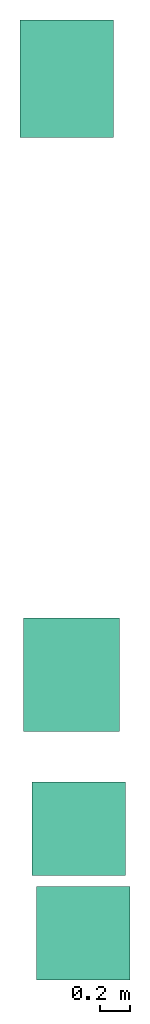
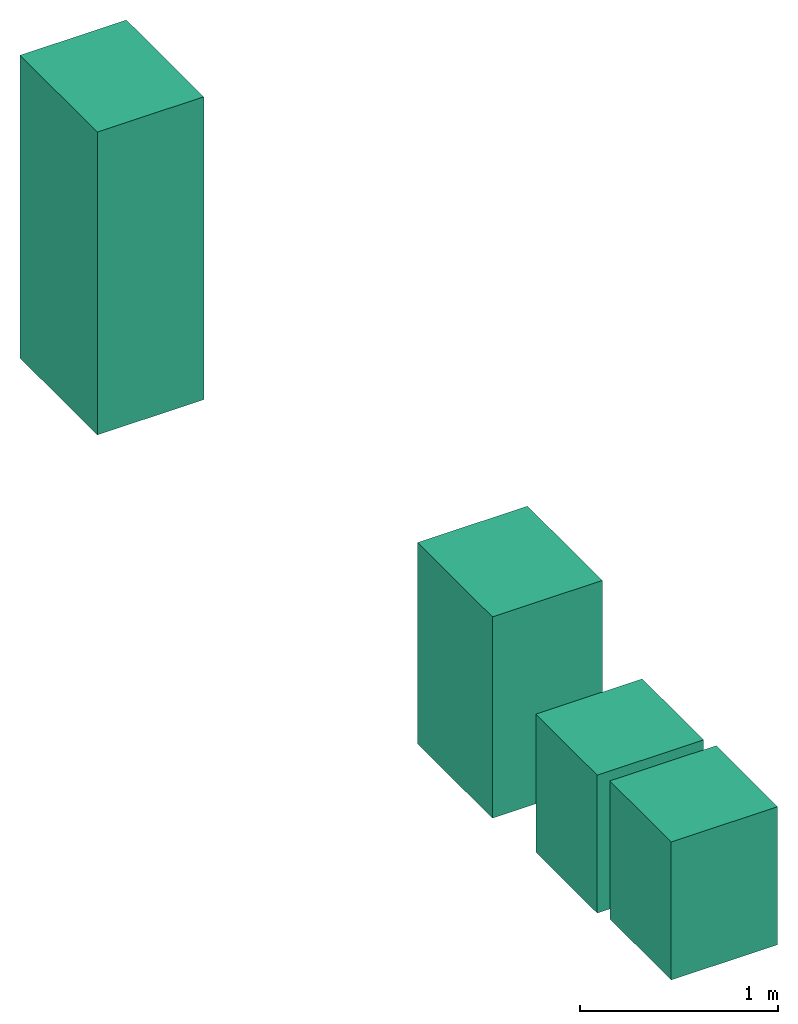
# Not in any storey: 4 electric appliances.
"""IFC4 building model written with IfcOpenShell, lengths in millimetres."""

import ifcopenshell
import ifcopenshell.guid

model = None  # the IFC model being written
_history = None  # IfcOwnerHistory: only IFC2X3 demands one
_inside = {}  # id of a spatial element -> (the spatial element, [elements in it])
_under = {}  # id of a project, library or spatial element -> (it, [spatial elements below it])
_declared = {}  # id of a project -> (the project, [libraries it declares])
_typed = {}  # id of a type object -> (the type object, [elements of that type])
_made_of = {}  # id of a material, layer set ... -> (it, [elements and type objects made of it])


def new_model(schema):
    """Start an empty IFC model of exactly this schema.

    Asked for "IFC4X3", IfcOpenShell would pick the latest addendum, in which some entities
    have other attributes; the version numbers below select the first issue.
    IFC2X3 requires an IfcOwnerHistory on every rooted entity: one is made here for all.
    """
    global model, _history
    if schema == "IFC4X3":
        model = ifcopenshell.file(schema_version=(4, 3, 0, 0))
    else:
        model = ifcopenshell.file(schema=schema)
    _inside.clear()
    _under.clear()
    _declared.clear()
    _typed.clear()
    _made_of.clear()
    _history = None
    if model.schema == "IFC2X3":
        org = make("IfcOrganization", Name="unknown")
        user = make(
            "IfcPersonAndOrganization",
            ThePerson=make("IfcPerson", FamilyName="unknown"),
            TheOrganization=org,
        )
        app = make(
            "IfcApplication",
            ApplicationDeveloper=org,
            Version="unknown",
            ApplicationFullName="unknown",
            ApplicationIdentifier="unknown",
        )
        _history = make(
            "IfcOwnerHistory",
            OwningUser=user,
            OwningApplication=app,
            ChangeAction="ADDED",
            CreationDate=0,
        )
    return model


def make(cls, **values):
    """One entity of the class cls with the attributes given. An attribute that is None is left unset."""
    return model.create_entity(
        cls, **{name: value for name, value in values.items() if value is not None}
    )


def entity(cls, *values):
    """Any entity or typed value of the class cls, its attributes in the order of the schema. None: left unset."""
    e = model.create_entity(cls)
    for i, value in enumerate(values):
        if value is not None:
            e[i] = value
    return e


def rooted(cls, **values):
    """An entity with a GlobalId (a new one), such as an element, a storey or a relation."""
    return make(cls, GlobalId=ifcopenshell.guid.new(), OwnerHistory=_history, **values)


def si_unit(unit_type, name, prefix=None):
    """IfcSIUnit, for example si_unit("LENGTHUNIT", "METRE", prefix="MILLI")."""
    return make("IfcSIUnit", UnitType=unit_type, Prefix=prefix, Name=name)


def converted_unit(unit_type, name, factor, base, dimensions=None, offset=None):
    """IfcConversionBasedUnit, such as the inch: factor (a typed value) times the base unit."""
    return make(
        "IfcConversionBasedUnit"
        if offset is None
        else "IfcConversionBasedUnitWithOffset",
        ConversionOffset=offset,
        Dimensions=None
        if dimensions is None
        else entity("IfcDimensionalExponents", *dimensions),
        UnitType=unit_type,
        Name=name,
        ConversionFactor=make(
            "IfcMeasureWithUnit", ValueComponent=factor, UnitComponent=base
        ),
    )


def assignment(units):
    """IfcUnitAssignment: the units of a project."""
    return None if units is None else make("IfcUnitAssignment", Units=units)


def point(xyz):
    """IfcCartesianPoint."""
    return None if xyz is None else make("IfcCartesianPoint", Coordinates=xyz)


def direction(xyz):
    """IfcDirection."""
    return None if xyz is None else make("IfcDirection", DirectionRatios=xyz)


def frame(location, z_axis=None, x_axis=None):
    """IfcAxis2Placement3D, a coordinate frame: its origin and axes. An axis left out is left unset."""
    return make(
        "IfcAxis2Placement3D",
        Location=point(location),
        Axis=direction(z_axis),
        RefDirection=direction(x_axis),
    )


def frame_2d(location, x_axis=None):
    """IfcAxis2Placement2D, a coordinate frame in the plane: its origin and x axis."""
    return make(
        "IfcAxis2Placement2D", Location=point(location), RefDirection=direction(x_axis)
    )


def origin_with_axes():
    """The frame at (0, 0, 0) with the z axis (0, 0, 1) and the x axis (1, 0, 0) written out."""
    return frame((0.0, 0.0, 0.0), z_axis=(0.0, 0.0, 1.0), x_axis=(1.0, 0.0, 0.0))


def origin_2d_with_axis():
    """The frame at (0, 0) in the plane with the x axis (1, 0) written out."""
    return frame_2d((0.0, 0.0), x_axis=(1.0, 0.0))


def place(relative_to, where):
    """IfcLocalPlacement: puts the frame where relative to a parent placement (None: the world)."""
    return make(
        "IfcLocalPlacement", PlacementRelTo=relative_to, RelativePlacement=where
    )


def context(
    kind, dimensions, precision=None, world=None, true_north=None, identifier=None
):
    """IfcGeometricRepresentationContext, for example the 3D "Model" context."""
    return make(
        "IfcGeometricRepresentationContext",
        ContextIdentifier=identifier,
        ContextType=kind,
        CoordinateSpaceDimension=dimensions,
        Precision=precision,
        WorldCoordinateSystem=world,
        TrueNorth=true_north,
    )


def subcontext(parent, identifier, kind, view, scale=None):
    """IfcGeometricRepresentationSubContext, for example "Body" below "Model"."""
    return make(
        "IfcGeometricRepresentationSubContext",
        ContextIdentifier=identifier,
        ContextType=kind,
        ParentContext=parent,
        TargetScale=scale,
        TargetView=view,
    )


def project(units=None, contexts=None):
    """IfcProject with its units and contexts."""
    return rooted(
        "IfcProject",
        Name="project",
        RepresentationContexts=contexts,
        UnitsInContext=assignment(units),
    )


def spatial(cls, under=None, at=None, **own):
    """A site, building, storey or space (cls), placed at a placement, below another one or the project."""
    s = rooted(cls, ObjectPlacement=at, **own)
    if under is not None:
        _under.setdefault(under.id(), (under, []))[1].append(s)
    return s


def point_list(points):
    """IfcCartesianPointList2D or 3D."""
    cls = (
        "IfcCartesianPointList2D" if len(points[0]) == 2 else "IfcCartesianPointList3D"
    )
    return make(cls, CoordList=points)


def polygons(points, faces, closed=None, point_numbers=None):
    """IfcPolygonalFaceSet: a face is its outer loop, then its inner loops; points numbered from 1."""
    made = []
    for loops in faces:
        if len(loops) == 1:
            made.append(make("IfcIndexedPolygonalFace", CoordIndex=loops[0]))
        else:
            made.append(
                make(
                    "IfcIndexedPolygonalFaceWithVoids",
                    CoordIndex=loops[0],
                    InnerCoordIndices=loops[1:],
                )
            )
    return make(
        "IfcPolygonalFaceSet",
        Coordinates=point_list(points),
        Closed=closed,
        Faces=made,
        PnIndex=point_numbers,
    )


def shape(context_of_items, identifier, shape_type, items):
    """IfcShapeRepresentation: the items that make up one representation, for example the "Body"."""
    return make(
        "IfcShapeRepresentation",
        ContextOfItems=context_of_items,
        RepresentationIdentifier=identifier,
        RepresentationType=shape_type,
        Items=items,
    )


def source(mapping_origin, context_of_items, identifier, shape_type, items):
    """IfcRepresentationMap: a shape defined once, which mapped items show again and again."""
    return make(
        "IfcRepresentationMap",
        MappingOrigin=mapping_origin,
        MappedRepresentation=shape(context_of_items, identifier, shape_type, items),
    )


def transform(
    local_origin,
    x_axis=None,
    y_axis=None,
    z_axis=None,
    scale=None,
    scale2=None,
    scale3=None,
    uniform=True,
):
    """IfcCartesianTransformationOperator3D, or its non-uniform kind. x_axis, y_axis, z_axis: its Axis1, 2, 3."""
    if uniform:
        return make(
            "IfcCartesianTransformationOperator3D",
            Axis1=direction(x_axis),
            Axis2=direction(y_axis),
            LocalOrigin=point(local_origin),
            Scale=scale,
            Axis3=direction(z_axis),
        )
    return make(
        "IfcCartesianTransformationOperator3DnonUniform",
        Axis1=direction(x_axis),
        Axis2=direction(y_axis),
        LocalOrigin=point(local_origin),
        Scale=scale,
        Axis3=direction(z_axis),
        Scale2=scale2,
        Scale3=scale3,
    )


def mapped(mapping_source, mapping_target):
    """IfcMappedItem: shows the shape of a source again, moved by a transform."""
    return make(
        "IfcMappedItem", MappingSource=mapping_source, MappingTarget=mapping_target
    )


def made_of(thing, what):
    """Note that an element or type object is made of a material, layer set ...; save() writes the relation."""
    if what is not None:
        _made_of.setdefault(what.id(), (what, []))[1].append(thing)
    return thing


def type_object(cls, material=None, **own):
    """A type object (cls), such as IfcWallType, which elements share."""
    return made_of(rooted(cls, **own), material)


def type_shapes(of_type, sources):
    """Give a type object the sources (RepresentationMaps) that its elements show as mapped items."""
    of_type.RepresentationMaps = sources


def element(
    cls,
    number,
    at=None,
    inside=None,
    cuts=None,
    type_object=None,
    material=None,
    context=None,
    identifier="Body",
    shape_type=None,
    held_by="IfcProductDefinitionShape",
    body=None,
    shapes=None,
    **own,
):
    """One element of the class cls, such as IfcWall. Its Tag is "e" and its number.

    at: its placement. inside: the storey or other place that contains it. cuts: it is an
    opening in that element (IfcRelVoidsElement). A single representation is given by context,
    identifier, shape_type and body (its items); several are given by shapes. held_by: the class
    of the entity that holds the representations. save() writes the other relations.
    """
    e = rooted(cls, Tag="e%d" % number, ObjectPlacement=at, **own)
    if body is not None:
        shapes = [shape(context, identifier, shape_type, body)]
    if shapes is not None:
        e.Representation = make(held_by, Representations=shapes)
    if inside is not None:
        _inside.setdefault(inside.id(), (inside, []))[1].append(e)
    if cuts is not None:
        rooted(
            "IfcRelVoidsElement", RelatingBuildingElement=cuts, RelatedOpeningElement=e
        )
    if type_object is not None:
        _typed.setdefault(type_object.id(), (type_object, []))[1].append(e)
    return made_of(e, material)


def aggregate(whole, parts):
    """IfcRelAggregates: a whole, such as a stair, and the parts it consists of."""
    return rooted("IfcRelAggregates", RelatingObject=whole, RelatedObjects=parts)


def save(model, path):
    """Write the relations noted so far, then the file.

    IfcRelAggregates (storeys below a building ...), IfcRelContainedInSpatialStructure (elements
    in a storey), IfcRelDefinesByType, IfcRelAssociatesMaterial and IfcRelDeclares: one each for
    every whole, place, type object, material and project.
    """
    for whole, parts in _under.values():
        aggregate(whole, parts)
    for where, things in _inside.values():
        rooted(
            "IfcRelContainedInSpatialStructure",
            RelatedElements=things,
            RelatingStructure=where,
        )
    for kind, things in _typed.values():
        rooted("IfcRelDefinesByType", RelatedObjects=things, RelatingType=kind)
    for what, things in _made_of.values():
        rooted("IfcRelAssociatesMaterial", RelatedObjects=things, RelatingMaterial=what)
    for by, libraries in _declared.values():
        rooted("IfcRelDeclares", RelatingContext=by, RelatedDefinitions=libraries)
    model.write(path)


model = new_model("IFC4")

# Units and contexts
model_context = context("Model", 3, precision=1e-05, world=origin_with_axes())
plan_context = context("Plan", 2, precision=1e-05, world=origin_2d_with_axis())
body_context = subcontext(model_context, "Body", "Model", "MODEL_VIEW")
ifc_project = project(units=[si_unit("VOLUMEUNIT", "CUBIC_METRE"), si_unit("LENGTHUNIT", "METRE", prefix="MILLI"), converted_unit("PLANEANGLEUNIT", "degree", entity("IfcReal", 0.0174532925199433), si_unit("PLANEANGLEUNIT", "RADIAN"), dimensions=[0, 0, 0, 0, 0, 0, 0]), si_unit("AREAUNIT", "SQUARE_METRE")], contexts=[model_context, plan_context])

# Site, buildings
site_placement = place(None, origin_with_axes())
site = spatial("IfcSite", under=ifc_project, at=site_placement)
building_1_placement = place(site_placement, origin_with_axes())
building_1 = spatial("IfcBuilding", under=site, at=building_1_placement, Name="Building")
building_2_placement = place(building_1_placement, origin_with_axes())
building_2 = spatial("IfcBuilding", under=building_1, at=building_2_placement, Name="Electrical")

# Electric appliances
electric_appliance_type_1 = type_object("IfcElectricApplianceType", Name="13 plate DW", PredefinedType="DISHWASHER")
shared_shape_1 = source(origin_with_axes(), body_context, "Body", "Tessellation", [
    polygons([(-25.4548778533936, -5.45489740371704, 2.98023205687059e-05), (-25.4548778533936, 614.544921875, 2.98023205687059e-05), (-25.4548778533936, -5.45489740371704, 850.0), (-25.4548778533936, 614.544921875, 850.0), (594.545043945312, 614.544921875, 2.98023205687059e-05), (594.545043945312, 614.544921875, 850.0), (594.545043945312, -5.45489740371704, 2.98023205687059e-05), (594.545043945312, -5.45489740371704, 850.0)], [[[2, 4, 6, 5]], [[5, 6, 8, 7]], [[7, 1, 2, 5]], [[3, 8, 6, 4]], [[3, 1, 7, 8]], [[4, 2, 1, 3]]], closed=True),
])
type_shapes(electric_appliance_type_1, [shared_shape_1])
electric_appliance_1_placement = place(building_2_placement, frame((1639.33420181274, 2875.96201896667, 0.0), z_axis=(0.0, 0.0, 1.0), x_axis=(1.0, 0.0, 0.0)))
element("IfcElectricAppliance", 1, at=electric_appliance_1_placement, inside=building_2, type_object=electric_appliance_type_1, Name="ElectricAppliance", context=body_context, shape_type="MappedRepresentation", body=[
    mapped(shared_shape_1, transform((0.0, 0.0, 0.0), x_axis=(1.0, 0.0, 0.0), y_axis=(0.0, 1.0, 0.0), z_axis=(0.0, 0.0, 1.0), scale=1.0)),
])
electric_appliance_type_2 = type_object("IfcElectricApplianceType", PredefinedType="WASHINGMACHINE")
shared_shape_2 = source(origin_with_axes(), body_context, "Body", "Tessellation", [
    polygons([(1.86264496733202e-05, 0.0, 2.98023205687059e-05), (1.86264496733202e-05, 619.999938964844, 2.98023205687059e-05), (1.86264496733202e-05, 0.0, 850.0), (1.86264496733202e-05, 619.999938964844, 850.0), (619.999938964844, 619.999938964844, 2.98023205687059e-05), (619.999938964844, 619.999938964844, 850.0), (619.999938964844, 0.0, 2.98023205687059e-05), (619.999938964844, 0.0, 850.0)], [[[2, 4, 6, 5]], [[5, 6, 8, 7]], [[7, 1, 2, 5]], [[3, 8, 6, 4]], [[3, 1, 7, 8]], [[4, 2, 1, 3]]], closed=True),
])
type_shapes(electric_appliance_type_2, [shared_shape_2])
electric_appliance_2_placement = place(building_2_placement, frame((1643.49460601807, 2175.20189285278, 0.0), z_axis=(0.0, 0.0, 1.0), x_axis=(1.0, 0.0, 0.0)))
element("IfcElectricAppliance", 2, at=electric_appliance_2_placement, inside=building_2, type_object=electric_appliance_type_2, Name="ElectricAppliance", context=body_context, shape_type="MappedRepresentation", body=[
    mapped(shared_shape_2, transform((0.0, 0.0, 0.0), x_axis=(1.0, 0.0, 0.0), y_axis=(0.0, 1.0, 0.0), z_axis=(0.0, 0.0, 1.0), scale=1.0)),
])
electric_appliance_type_3 = type_object("IfcElectricApplianceType", PredefinedType="FRIDGE_FREEZER")
shared_shape_3 = source(origin_with_axes(), body_context, "Body", "Tessellation", [
    polygons([(2.98023187497165e-05, 779.999877929688, 2.98023187497165e-05), (619.999877929688, 779.999877929688, 2.98023187497165e-05), (2.98023187497165e-05, 779.999877929688, 1864.99975585938), (619.999877929688, 779.999877929688, 1864.99975585938), (619.999877929688, 2.98023187497165e-05, 2.98023187497165e-05), (619.999877929688, 2.98023187497165e-05, 1864.99975585938), (2.98023187497165e-05, 2.98023187497165e-05, 2.98023187497165e-05), (2.98023187497165e-05, 2.98023187497165e-05, 1864.99975585938)], [[[2, 1, 3]], [[2, 3, 4]], [[6, 5, 2]], [[6, 2, 4]], [[1, 2, 5]], [[1, 5, 7]], [[4, 3, 8]], [[4, 8, 6]], [[5, 6, 8]], [[5, 8, 7]], [[8, 3, 1]], [[8, 1, 7]]], closed=True),
])
type_shapes(electric_appliance_type_3, [shared_shape_3])
electric_appliance_3_placement = place(building_2_placement, frame((2153.04899215698, 8553.37905883789, 0.0), z_axis=(0.0, 0.0, 1.0), x_axis=(-0.999999999999989, 1.50995802528085e-07, 0.0)))
element("IfcElectricAppliance", 3, at=electric_appliance_3_placement, inside=building_2, type_object=electric_appliance_type_3, Name="ElectricAppliance", context=body_context, shape_type="MappedRepresentation", body=[
    mapped(shared_shape_3, transform((0.0, 0.0, 0.0), x_axis=(1.0, 0.0, 0.0), y_axis=(0.0, 1.0, 0.0), z_axis=(0.0, 0.0, 1.0), scale=1.0)),
])
electric_appliance_type_4 = type_object("IfcElectricApplianceType", PredefinedType="ELECTRICCOOKER")
shared_shape_4 = source(origin_with_axes(), body_context, "Body", "Tessellation", [
    polygons([(-3.21423983573914, 11.3971147537231, 26.0084190368652), (-3.21423983573914, 11.3971147537231, 1266.00842285156), (-3.21423983573914, 651.397094726562, 26.0084190368652), (-3.21423983573914, 651.397094726562, 1266.00842285156), (751.785705566406, 11.3971147537231, 26.0084190368652), (751.785705566406, 11.3971147537231, 1266.00842285156), (751.785705566406, 651.397094726562, 26.0084190368652), (751.785705566406, 651.397094726562, 1266.00842285156)], [[[1, 2, 4, 3]], [[3, 4, 8, 7]], [[7, 8, 6, 5]], [[5, 6, 2, 1]], [[3, 7, 5, 1]], [[8, 4, 2, 6]]], closed=True),
])
type_shapes(electric_appliance_type_4, [shared_shape_4])
electric_appliance_4_placement = place(building_2_placement, frame((1543.6372756958, 4577.67343521118, 0.0), z_axis=(0.0, 0.0, 1.0), x_axis=(7.54979012640431e-08, -0.999999999999997, 0.0)))
element("IfcElectricAppliance", 4, at=electric_appliance_4_placement, inside=building_2, type_object=electric_appliance_type_4, Name="ElectricAppliance", context=body_context, shape_type="MappedRepresentation", body=[
    mapped(shared_shape_4, transform((0.0, 0.0, 0.0), x_axis=(1.0, 0.0, 0.0), y_axis=(0.0, 1.0, 0.0), z_axis=(0.0, 0.0, 1.0), scale=1.0)),
])

save(model, "model.ifc")
